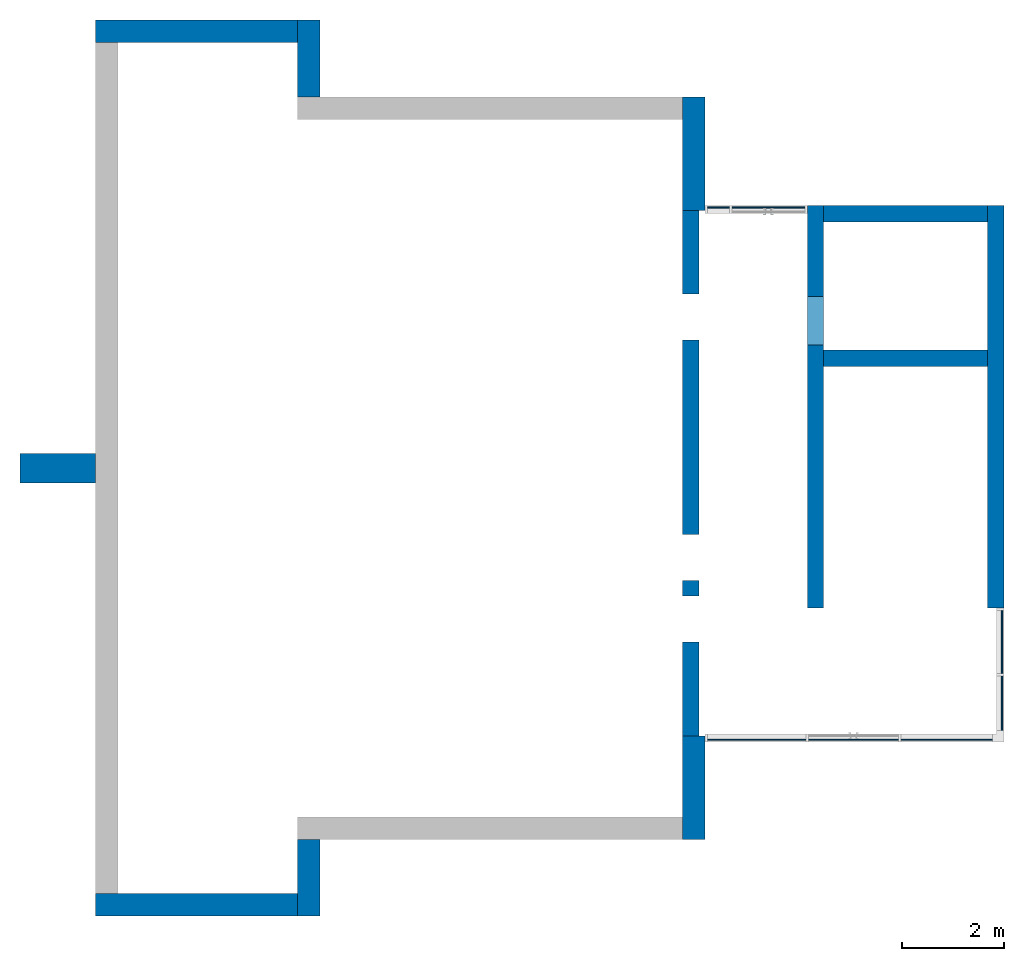
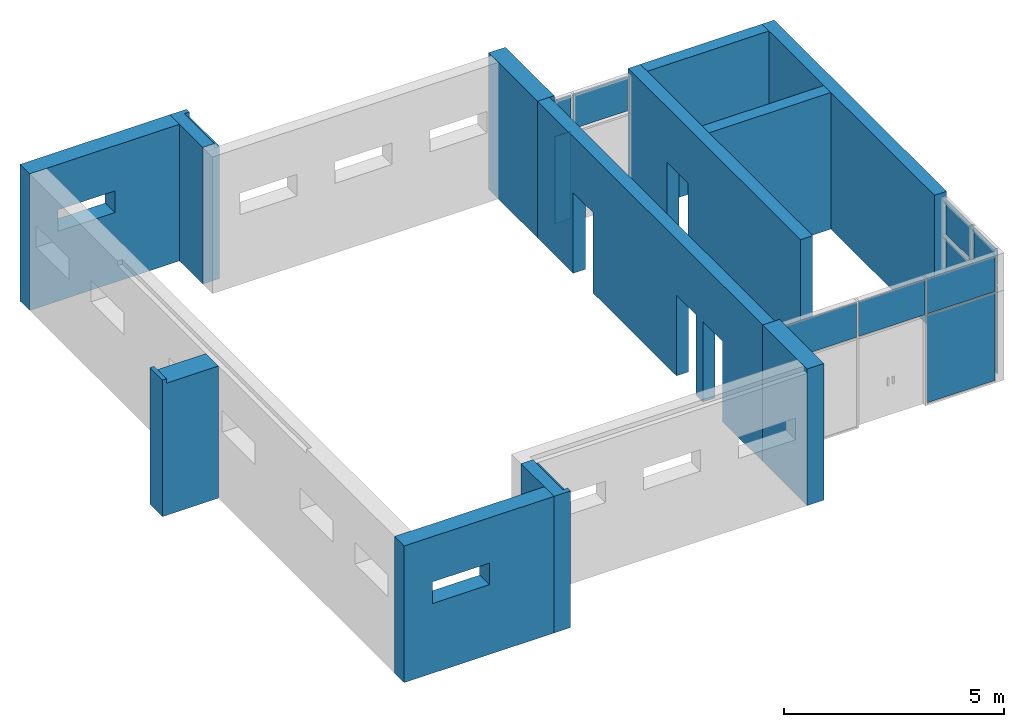
# One storey, part 2 of 4: 12 walls, 11 plates, 6 openings, 3 elements without a shape of their own.
"""IFC2X3 building model written with IfcOpenShell, lengths in millimetres."""

from ifc_helpers import new_model, entity, si_unit, converted_unit, derived_unit, direction, frame, frame_2d, origin, origin_2d_with_axis, place, context, subcontext, project, spatial, polyline, rectangle, extrude, clip, bounded_halfspace, faceted_brep, source, transform, mapped, material, layer, layer_set, layer_usage, type_object, type_shapes, element, aggregate, save


model = new_model("IFC2X3")

# Units and contexts
model_context = context("Model", 3, precision=0.01, world=origin(), true_north=direction((6.12303176911189e-17, 1.0)))
body_context = subcontext(model_context, "Body", "Model", "MODEL_VIEW")
ifc_project = project(units=[si_unit("LENGTHUNIT", "METRE", prefix="MILLI"), si_unit("AREAUNIT", "SQUARE_METRE"), si_unit("VOLUMEUNIT", "CUBIC_METRE"), converted_unit("PLANEANGLEUNIT", "DEGREE", entity("IfcRatioMeasure", 0.0174532925199433), si_unit("PLANEANGLEUNIT", "RADIAN"), dimensions=[0, 0, 0, 0, 0, 0, 0]), si_unit("MASSUNIT", "GRAM", prefix="KILO"), derived_unit("MASSDENSITYUNIT", [(si_unit("MASSUNIT", "GRAM", prefix="KILO"), 1), (si_unit("LENGTHUNIT", "METRE"), -3)]), si_unit("TIMEUNIT", "SECOND"), si_unit("FREQUENCYUNIT", "HERTZ"), si_unit("THERMODYNAMICTEMPERATUREUNIT", "DEGREE_CELSIUS"), derived_unit("THERMALTRANSMITTANCEUNIT", [(si_unit("MASSUNIT", "GRAM", prefix="KILO"), 1), (si_unit("THERMODYNAMICTEMPERATUREUNIT", "KELVIN"), -1), (si_unit("TIMEUNIT", "SECOND"), -3)]), derived_unit("VOLUMETRICFLOWRATEUNIT", [(si_unit("LENGTHUNIT", "METRE"), 3), (si_unit("TIMEUNIT", "SECOND"), -1)]), si_unit("ELECTRICCURRENTUNIT", "AMPERE"), si_unit("ELECTRICVOLTAGEUNIT", "VOLT"), si_unit("POWERUNIT", "WATT"), si_unit("FORCEUNIT", "NEWTON", prefix="KILO"), si_unit("ILLUMINANCEUNIT", "LUX"), si_unit("LUMINOUSFLUXUNIT", "LUMEN"), si_unit("LUMINOUSINTENSITYUNIT", "CANDELA"), derived_unit("USERDEFINED", [(si_unit("MASSUNIT", "GRAM", prefix="KILO"), -1), (si_unit("LENGTHUNIT", "METRE"), -2), (si_unit("TIMEUNIT", "SECOND"), 3), (si_unit("LUMINOUSFLUXUNIT", "LUMEN"), 1)]), derived_unit("LINEARVELOCITYUNIT", [(si_unit("LENGTHUNIT", "METRE"), 1), (si_unit("TIMEUNIT", "SECOND"), -1)]), si_unit("PRESSUREUNIT", "PASCAL"), derived_unit("USERDEFINED", [(si_unit("LENGTHUNIT", "METRE"), -2), (si_unit("MASSUNIT", "GRAM", prefix="KILO"), 1), (si_unit("TIMEUNIT", "SECOND"), -2)])], contexts=[model_context])

# Site, building, storey
site_placement = place(None, origin())
site = spatial("IfcSite", under=ifc_project, at=site_placement, CompositionType="ELEMENT")
building_placement = place(site_placement, origin())
building = spatial("IfcBuilding", under=site, at=building_placement, CompositionType="ELEMENT")
storey_placement = place(building_placement, origin())
storey = spatial("IfcBuildingStorey", under=building, at=storey_placement, Name="00 Ground level", CompositionType="ELEMENT", Elevation=0.0)

# Curtain wall, plates
curtain_wall_type = type_object("IfcCurtainWallType", Name="Curtain Wall", PredefinedType="NOTDEFINED")
curtain_wall_1_placement = place(storey_placement, origin())
curtain_wall_1 = element("IfcCurtainWall", 1, at=curtain_wall_1_placement, inside=storey, type_object=curtain_wall_type, Name="Curtain Wall", ObjectType="Curtain Wall")
ifc_material_1 = material()
ifc_layer_1 = layer(ifc_material_1, 25.0)
ifc_layer_set_1 = layer_set([ifc_layer_1], Name="System Panel:Glazed")
ifc_layer_usage_1 = layer_usage(ifc_layer_set_1, "AXIS3", "POSITIVE", 0.121391076115486)
plate_type_1 = type_object("IfcPlateType", Name="Glazed", PredefinedType="CURTAIN_PANEL", material=ifc_layer_set_1)
shared_shape_1 = source(origin(), body_context, "Body", "SweptSolid", [
    extrude(rectangle(XDim=25.0, YDim=1790.00000000007, at=frame_2d((2.66453525910038e-15, 0.0), x_axis=(1.0, 0.0))), frame((895.0, 12.5, 0.0), z_axis=(0.0, 0.0, 1.0), x_axis=(0.0, 1.0, 0.0)), (0.0, 0.0, 1.0), 2425.0),
])
type_shapes(plate_type_1, [shared_shape_1])
plate_1_placement = place(curtain_wall_1_placement, frame((32768.4900708517, -74150.3241905963, 50.0)))
plate_1 = element("IfcPlate", 2, at=plate_1_placement, type_object=plate_type_1, material=ifc_layer_usage_1, Name="System Panel:Glazed", ObjectType="System Panel:Glazed", context=body_context, shape_type="MappedRepresentation", body=[
    mapped(shared_shape_1, transform((0.0, 0.0, 0.0), scale=1.0)),
])
ifc_layer_usage_2 = layer_usage(ifc_layer_set_1, "AXIS3", "POSITIVE", 0.121391076115486)
plate_type_2 = type_object("IfcPlateType", Name="Glazed", PredefinedType="CURTAIN_PANEL", material=ifc_layer_set_1)
shared_shape_2 = source(origin(), body_context, "Body", "SweptSolid", [
    extrude(rectangle(XDim=25.0, YDim=1924.99999999991, at=frame_2d((2.66453525910038e-15, 0.0), x_axis=(1.0, 0.0))), frame((962.499999999957, 12.5, 0.0), z_axis=(0.0, 0.0, 1.0), x_axis=(0.0, 1.0, 0.0)), (0.0, 0.0, 1.0), 960.0),
])
type_shapes(plate_type_2, [shared_shape_2])
plate_2_placement = place(curtain_wall_1_placement, frame((28993.4900708518, -74150.3241905963, 2525.0)))
plate_2 = element("IfcPlate", 3, at=plate_2_placement, type_object=plate_type_2, material=ifc_layer_usage_2, Name="System Panel:Glazed", ObjectType="System Panel:Glazed", context=body_context, shape_type="MappedRepresentation", body=[
    mapped(shared_shape_2, transform((0.0, 0.0, 0.0), scale=1.0)),
])
ifc_layer_usage_3 = layer_usage(ifc_layer_set_1, "AXIS3", "POSITIVE", 0.121391076115486)
plate_type_3 = type_object("IfcPlateType", Name="Glazed", PredefinedType="CURTAIN_PANEL", material=ifc_layer_set_1)
shared_shape_3 = source(origin(), body_context, "Body", "SweptSolid", [
    extrude(rectangle(XDim=25.0, YDim=1750.0, at=frame_2d((2.66453525910038e-15, 0.0), x_axis=(1.0, 0.0))), frame((875.0, 12.5, 0.0), z_axis=(0.0, 0.0, 1.0), x_axis=(0.0, 1.0, 0.0)), (0.0, 0.0, 1.0), 960.0),
])
type_shapes(plate_type_3, [shared_shape_3])
plate_3_placement = place(curtain_wall_1_placement, frame((30968.4900708517, -74150.3241905963, 2525.0)))
plate_3 = element("IfcPlate", 4, at=plate_3_placement, type_object=plate_type_3, material=ifc_layer_usage_3, Name="System Panel:Glazed", ObjectType="System Panel:Glazed", context=body_context, shape_type="MappedRepresentation", body=[
    mapped(shared_shape_3, transform((0.0, 0.0, 0.0), scale=1.0)),
])
ifc_layer_usage_4 = layer_usage(ifc_layer_set_1, "AXIS3", "POSITIVE", 0.121391076115486)
plate_type_4 = type_object("IfcPlateType", Name="Glazed", PredefinedType="CURTAIN_PANEL", material=ifc_layer_set_1)
shared_shape_4 = source(origin(), body_context, "Body", "SweptSolid", [
    extrude(rectangle(XDim=25.0, YDim=1790.00000000007, at=frame_2d((2.66453525910038e-15, 0.0), x_axis=(1.0, 0.0))), frame((895.0, 12.5, 0.0), z_axis=(0.0, 0.0, 1.0), x_axis=(0.0, 1.0, 0.0)), (0.0, 0.0, 1.0), 960.0),
])
type_shapes(plate_type_4, [shared_shape_4])
plate_4_placement = place(curtain_wall_1_placement, frame((32768.4900708517, -74150.3241905963, 2525.0)))
plate_4 = element("IfcPlate", 5, at=plate_4_placement, type_object=plate_type_4, material=ifc_layer_usage_4, Name="System Panel:Glazed", ObjectType="System Panel:Glazed", context=body_context, shape_type="MappedRepresentation", body=[
    mapped(shared_shape_4, transform((0.0, 0.0, 0.0), scale=1.0)),
])
aggregate(curtain_wall_1, [plate_1, plate_2, plate_3, plate_4])

curtain_wall_2_placement = place(storey_placement, origin())
curtain_wall_2 = element("IfcCurtainWall", 6, at=curtain_wall_2_placement, inside=storey, type_object=curtain_wall_type, Name="Curtain Wall", ObjectType="Curtain Wall")
ifc_layer_usage_5 = layer_usage(ifc_layer_set_1, "AXIS3", "POSITIVE", 0.121391076115486)
plate_type_5 = type_object("IfcPlateType", Name="Glazed", PredefinedType="CURTAIN_PANEL", material=ifc_layer_set_1)
shared_shape_5 = source(origin(), body_context, "Body", "SweptSolid", [
    extrude(rectangle(XDim=25.0, YDim=1057.49999999999, at=origin_2d_with_axis()), frame((528.749999999997, 12.5, 0.0), z_axis=(0.0, 0.0, 1.0), x_axis=(0.0, 1.0, 0.0)), (0.0, 0.0, 1.0), 2425.0),
])
type_shapes(plate_type_5, [shared_shape_5])
plate_5_placement = place(curtain_wall_2_placement, frame((34757.9900708518, -73950.8241905963, 50.0), z_axis=(0.0, 0.0, 1.0), x_axis=(0.0, 1.0, 0.0)))
plate_5 = element("IfcPlate", 7, at=plate_5_placement, type_object=plate_type_5, material=ifc_layer_usage_5, Name="System Panel:Glazed", ObjectType="System Panel:Glazed", context=body_context, shape_type="MappedRepresentation", body=[
    mapped(shared_shape_5, transform((0.0, 0.0, 0.0), scale=1.0)),
])
ifc_layer_usage_6 = layer_usage(ifc_layer_set_1, "AXIS3", "POSITIVE", 0.121391076115486)
plate_type_6 = type_object("IfcPlateType", Name="Glazed", PredefinedType="CURTAIN_PANEL", material=ifc_layer_set_1)
shared_shape_6 = source(origin(), body_context, "Body", "SweptSolid", [
    extrude(rectangle(XDim=25.0, YDim=1232.49999999999, at=frame_2d((-1.77635683940025e-15, 0.0), x_axis=(1.0, 0.0))), frame((616.249999999994, 12.5, 0.0), z_axis=(0.0, 0.0, 1.0), x_axis=(0.0, 1.0, 0.0)), (0.0, 0.0, 1.0), 2425.0),
])
type_shapes(plate_type_6, [shared_shape_6])
plate_6_placement = place(curtain_wall_2_placement, frame((34757.9900708518, -72843.3241905963, 50.0), z_axis=(0.0, 0.0, 1.0), x_axis=(0.0, 1.0, 0.0)))
plate_6 = element("IfcPlate", 8, at=plate_6_placement, type_object=plate_type_6, material=ifc_layer_usage_6, Name="System Panel:Glazed", ObjectType="System Panel:Glazed", context=body_context, shape_type="MappedRepresentation", body=[
    mapped(shared_shape_6, transform((0.0, 0.0, 0.0), scale=1.0)),
])
ifc_layer_usage_7 = layer_usage(ifc_layer_set_1, "AXIS3", "POSITIVE", 0.121391076115486)
plate_type_7 = type_object("IfcPlateType", Name="Glazed", PredefinedType="CURTAIN_PANEL", material=ifc_layer_set_1)
shared_shape_7 = source(origin(), body_context, "Body", "SweptSolid", [
    extrude(rectangle(XDim=25.0, YDim=1057.49999999999, at=origin_2d_with_axis()), frame((528.749999999997, 12.5, 0.0), z_axis=(0.0, 0.0, 1.0), x_axis=(0.0, 1.0, 0.0)), (0.0, 0.0, 1.0), 960.0),
])
type_shapes(plate_type_7, [shared_shape_7])
plate_7_placement = place(curtain_wall_2_placement, frame((34757.9900708518, -73950.8241905963, 2525.0), z_axis=(0.0, 0.0, 1.0), x_axis=(0.0, 1.0, 0.0)))
plate_7 = element("IfcPlate", 9, at=plate_7_placement, type_object=plate_type_7, material=ifc_layer_usage_7, Name="System Panel:Glazed", ObjectType="System Panel:Glazed", context=body_context, shape_type="MappedRepresentation", body=[
    mapped(shared_shape_7, transform((0.0, 0.0, 0.0), scale=1.0)),
])
ifc_layer_usage_8 = layer_usage(ifc_layer_set_1, "AXIS3", "POSITIVE", 0.121391076115486)
plate_type_8 = type_object("IfcPlateType", Name="Glazed", PredefinedType="CURTAIN_PANEL", material=ifc_layer_set_1)
shared_shape_8 = source(origin(), body_context, "Body", "SweptSolid", [
    extrude(rectangle(XDim=25.0, YDim=1232.49999999999, at=frame_2d((-1.77635683940025e-15, 0.0), x_axis=(1.0, 0.0))), frame((616.249999999994, 12.5, 0.0), z_axis=(0.0, 0.0, 1.0), x_axis=(0.0, 1.0, 0.0)), (0.0, 0.0, 1.0), 960.0),
])
type_shapes(plate_type_8, [shared_shape_8])
plate_8_placement = place(curtain_wall_2_placement, frame((34757.9900708518, -72843.3241905963, 2525.0), z_axis=(0.0, 0.0, 1.0), x_axis=(0.0, 1.0, 0.0)))
plate_8 = element("IfcPlate", 10, at=plate_8_placement, type_object=plate_type_8, material=ifc_layer_usage_8, Name="System Panel:Glazed", ObjectType="System Panel:Glazed", context=body_context, shape_type="MappedRepresentation", body=[
    mapped(shared_shape_8, transform((0.0, 0.0, 0.0), scale=1.0)),
])
aggregate(curtain_wall_2, [plate_5, plate_6, plate_7, plate_8])

curtain_wall_3_placement = place(storey_placement, origin())
curtain_wall_3 = element("IfcCurtainWall", 11, at=curtain_wall_3_placement, inside=storey, type_object=curtain_wall_type, Name="Curtain Wall", ObjectType="Curtain Wall")
ifc_layer_usage_9 = layer_usage(ifc_layer_set_1, "AXIS3", "POSITIVE", 0.121391076115486)
plate_type_9 = type_object("IfcPlateType", Name="Glazed", PredefinedType="CURTAIN_PANEL", material=ifc_layer_set_1)
shared_shape_9 = source(origin(), body_context, "Body", "SweptSolid", [
    extrude(rectangle(XDim=25.0, YDim=425.000000000016, at=frame_2d((2.66453525910038e-15, 0.0), x_axis=(1.0, 0.0))), frame((212.500000000008, 12.5, 0.0), z_axis=(0.0, 0.0, 1.0), x_axis=(0.0, 1.0, 0.0)), (0.0, 0.0, 1.0), 2425.0),
])
type_shapes(plate_type_9, [shared_shape_9])
plate_9_placement = place(curtain_wall_3_placement, frame((29418.4900708518, -63731.3241905964, 50.0), z_axis=(0.0, 0.0, 1.0), x_axis=(-1.0, 0.0, 0.0)))
plate_9 = element("IfcPlate", 12, at=plate_9_placement, type_object=plate_type_9, material=ifc_layer_usage_9, Name="System Panel:Glazed", ObjectType="System Panel:Glazed", context=body_context, shape_type="MappedRepresentation", body=[
    mapped(shared_shape_9, transform((0.0, 0.0, 0.0), scale=1.0)),
])
ifc_layer_usage_10 = layer_usage(ifc_layer_set_1, "AXIS3", "POSITIVE", 0.121391076115486)
plate_type_10 = type_object("IfcPlateType", Name="Glazed", PredefinedType="CURTAIN_PANEL", material=ifc_layer_set_1)
shared_shape_10 = source(origin(), body_context, "Body", "SweptSolid", [
    extrude(rectangle(XDim=25.0, YDim=1425.0, at=frame_2d((2.66453525910038e-15, 0.0), x_axis=(1.0, 0.0))), frame((712.5, 12.5, 0.0), z_axis=(0.0, 0.0, 1.0), x_axis=(0.0, 1.0, 0.0)), (0.0, 0.0, 1.0), 960.0),
])
type_shapes(plate_type_10, [shared_shape_10])
plate_10_placement = place(curtain_wall_3_placement, frame((30893.4900708518, -63731.3241905964, 2525.0), z_axis=(0.0, 0.0, 1.0), x_axis=(-1.0, 0.0, 0.0)))
plate_10 = element("IfcPlate", 13, at=plate_10_placement, type_object=plate_type_10, material=ifc_layer_usage_10, Name="System Panel:Glazed", ObjectType="System Panel:Glazed", context=body_context, shape_type="MappedRepresentation", body=[
    mapped(shared_shape_10, transform((0.0, 0.0, 0.0), scale=1.0)),
])
ifc_layer_usage_11 = layer_usage(ifc_layer_set_1, "AXIS3", "POSITIVE", 0.121391076115486)
plate_type_11 = type_object("IfcPlateType", Name="Glazed", PredefinedType="CURTAIN_PANEL", material=ifc_layer_set_1)
shared_shape_11 = source(origin(), body_context, "Body", "SweptSolid", [
    extrude(rectangle(XDim=25.0, YDim=425.000000000016, at=frame_2d((2.66453525910038e-15, 0.0), x_axis=(1.0, 0.0))), frame((212.500000000008, 12.5, 0.0), z_axis=(0.0, 0.0, 1.0), x_axis=(0.0, 1.0, 0.0)), (0.0, 0.0, 1.0), 960.0),
])
type_shapes(plate_type_11, [shared_shape_11])
plate_11_placement = place(curtain_wall_3_placement, frame((29418.4900708518, -63731.3241905964, 2525.0), z_axis=(0.0, 0.0, 1.0), x_axis=(-1.0, 0.0, 0.0)))
plate_11 = element("IfcPlate", 14, at=plate_11_placement, type_object=plate_type_11, material=ifc_layer_usage_11, Name="System Panel:Glazed", ObjectType="System Panel:Glazed", context=body_context, shape_type="MappedRepresentation", body=[
    mapped(shared_shape_11, transform((0.0, 0.0, 0.0), scale=1.0)),
])
aggregate(curtain_wall_3, [plate_9, plate_10, plate_11])

# Walls
ifc_material_2 = material(Name="03")
ifc_layer_2 = layer(ifc_material_2, 10.0)
ifc_material_3 = material()
ifc_layer_3 = layer(ifc_material_3, 120.0)
ifc_material_4 = material()
ifc_layer_4 = layer(ifc_material_4, 300.0)
ifc_layer_5 = layer(ifc_material_2, 10.0)
ifc_layer_set_2 = layer_set([ifc_layer_2, ifc_layer_3, ifc_layer_4, ifc_layer_5], Name="Basic Wall:00_fal+12 cm")
ifc_layer_usage_12 = layer_usage(ifc_layer_set_2, "AXIS2", "NEGATIVE", 220.0)
wall_type_1 = type_object("IfcWallType", Name="Basic Wall:00_fal+12 cm", PredefinedType="STANDARD", material=ifc_layer_set_2)
wall_1_placement = place(storey_placement, frame((28723.4900708518, -61581.23958514, -140.0), z_axis=(0.0, 0.0, 1.0), x_axis=(0.0, -1.0, 0.0)))
element("IfcWallStandardCase", 15, at=wall_1_placement, inside=storey, type_object=wall_type_1, material=ifc_layer_usage_12, Name="Basic Wall:00_fal+12 cm", ObjectType="Basic Wall:00_fal+12 cm", context=body_context, shape_type="SweptSolid", body=[
    extrude(rectangle(XDim=2224.58460545637, YDim=440.000000000004, at=frame_2d((1112.29230272819, -1.84741111297626e-13), x_axis=(-1.0, 0.0))), origin(), (0.0, 0.0, 1.0), 3800.0),
])
wall_2_placement = place(storey_placement, frame((21203.4900708518, -76081.2395851399, -140.0), z_axis=(0.0, 0.0, 1.0), x_axis=(0.0, -1.0, 0.0)))
element("IfcWall", 16, at=wall_2_placement, inside=storey, type_object=wall_type_1, Name="Basic Wall:00_fal+12 cm", ObjectType="Basic Wall:00_fal+12 cm", context=body_context, shape_type="Brep", body=[
    faceted_brep([(0.0, -220.0, 0.0), (1060.0, -220.0, 0.0), (1500.0, -220.0, 0.0), (1500.0, -220.0, 3800.0), (1370.0, -220.0, 3800.0), (1060.0, -220.0, 3800.0), (0.0, -220.0, 3800.0), (1500.0, 220.0, 0.0), (0.0, 220.0, 0.0), (0.0, 220.0, 3675.0), (1370.0, 220.0, 3675.0), (1370.0, 220.0, 3800.0), (1500.0, 220.0, 3800.0), (1370.0, 90.0, 3800.0), (0.0, 90.0, 3800.0), (0.0, 90.0, 3675.0), (1370.0, 90.0, 3675.0)], [[[0, 1, 2, 3, 4, 5, 6]], [[7, 8, 9, 10, 11, 12]], [[2, 1, 0, 8, 7]], [[6, 5, 4, 3, 12, 11, 13, 14]], [[0, 6, 14, 15, 9, 8]], [[3, 2, 7, 12]], [[15, 16, 10, 9]], [[16, 13, 11, 10]], [[13, 16, 15, 14]]]),
])

# Wall, opening
ifc_layer_usage_13 = layer_usage(ifc_layer_set_2, "AXIS2", "NEGATIVE", 220.0)
wall_3_placement = place(storey_placement, frame((20983.4900708518, -77361.2395851399, -140.0), z_axis=(0.0, 0.0, 1.0), x_axis=(-1.0, 0.0, 0.0)))
wall_3 = element("IfcWallStandardCase", 17, at=wall_3_placement, inside=storey, type_object=wall_type_1, material=ifc_layer_usage_13, Name="Basic Wall:00_fal+12 cm", ObjectType="Basic Wall:00_fal+12 cm", context=body_context, shape_type="SweptSolid", body=[
    extrude(rectangle(XDim=3940.00000000002, YDim=440.000000000004, at=frame_2d((1970.00000000001, 0.0), x_axis=(-1.0, 0.0))), origin(), (0.0, 0.0, 1.0), 3800.0),
])
opening_1_placement = place(wall_3_placement, frame((3200.0, 1744.0, 1940.0), z_axis=(0.0, 0.0, 1.0), x_axis=(-1.0, 0.0, 0.0)))
element("IfcOpeningElement", 18, at=opening_1_placement, cuts=wall_3, Name="Basic Wall:00_fal+12 cm", ObjectType="Opening", context=body_context, shape_type="SweptSolid", body=[
    extrude(rectangle(XDim=599.999999999998, YDim=1500.0, at=frame_2d((0.0, 0.0), x_axis=(0.0, 1.0))), frame((750.0, 3048.0, 300.0), z_axis=(0.0, -1.0, 0.0), x_axis=(1.0, 0.0, 0.0)), (0.0, 0.0, 1.0), 3048.0),
])

# Wall
wall_4_placement = place(storey_placement, frame((21203.4900708518, -61581.2395851399, -140.0), z_axis=(0.0, 0.0, 1.0), x_axis=(0.0, 1.0, 0.0)))
element("IfcWall", 19, at=wall_4_placement, inside=storey, type_object=wall_type_1, Name="Basic Wall:00_fal+12 cm", ObjectType="Basic Wall:00_fal+12 cm", context=body_context, shape_type="Brep", body=[
    faceted_brep([(0.0, -220.0, 0.0), (1500.0, -220.0, 0.0), (1500.0, -220.0, 3800.0), (1370.0, -220.0, 3800.0), (1370.0, -220.0, 3675.0), (0.0, -220.0, 3675.0), (1500.0, 220.0, 0.0), (1060.0, 220.0, 0.0), (0.0, 220.0, 0.0), (0.0, 220.0, 3800.0), (1060.0, 220.0, 3800.0), (1370.0, 220.0, 3800.0), (1500.0, 220.0, 3800.0), (0.0, -90.0, 3800.0), (1370.0, -90.0, 3800.0), (0.0, -90.0, 3675.0), (1370.0, -90.0, 3675.0)], [[[0, 1, 2, 3, 4, 5]], [[6, 7, 8, 9, 10, 11, 12]], [[1, 0, 8, 7, 6]], [[12, 11, 10, 9, 13, 14, 3, 2]], [[9, 8, 0, 5, 15, 13]], [[2, 1, 6, 12]], [[4, 16, 15, 5]], [[16, 14, 13, 15]], [[14, 16, 4, 3]]]),
])

# Wall, opening
ifc_layer_usage_14 = layer_usage(ifc_layer_set_2, "AXIS2", "POSITIVE", -220.0)
wall_5_placement = place(storey_placement, frame((20983.4900708518, -60301.2395851399, -140.0), z_axis=(0.0, 0.0, 1.0), x_axis=(-1.0, 0.0, 0.0)))
wall_5 = element("IfcWallStandardCase", 20, at=wall_5_placement, inside=storey, type_object=wall_type_1, material=ifc_layer_usage_14, Name="Basic Wall:00_fal+12 cm", ObjectType="Basic Wall:00_fal+12 cm", context=body_context, shape_type="SweptSolid", body=[
    extrude(rectangle(XDim=3940.00000000004, YDim=440.000000000004, at=frame_2d((1970.00000000002, -1.08002495835535e-12), x_axis=(-1.0, 0.0))), origin(), (0.0, 0.0, 1.0), 3800.0),
])
opening_2_placement = place(wall_5_placement, frame((3200.0, 1304.0, 1940.0), z_axis=(0.0, 0.0, 1.0), x_axis=(-1.0, 0.0, 0.0)))
element("IfcOpeningElement", 21, at=opening_2_placement, cuts=wall_5, Name="Basic Wall:00_fal+12 cm", ObjectType="Opening", context=body_context, shape_type="SweptSolid", body=[
    extrude(rectangle(XDim=599.999999999998, YDim=1500.0, at=frame_2d((0.0, 0.0), x_axis=(0.0, 1.0))), frame((750.0, 3048.0, 300.0), z_axis=(0.0, -1.0, 0.0), x_axis=(1.0, 0.0, 0.0)), (0.0, 0.0, 1.0), 3048.0),
])

# Wall
ifc_layer_usage_15 = layer_usage(ifc_layer_set_2, "AXIS2", "NEGATIVE", 220.0)
wall_6_placement = place(storey_placement, frame((28723.4900708518, -74061.2395851399, -140.0), z_axis=(0.0, 0.0, 1.0), x_axis=(0.0, -1.0, 0.0)))
element("IfcWallStandardCase", 22, at=wall_6_placement, inside=storey, type_object=wall_type_1, material=ifc_layer_usage_15, Name="Basic Wall:00_fal+12 cm", ObjectType="Basic Wall:00_fal+12 cm", context=body_context, shape_type="SweptSolid", body=[
    extrude(rectangle(XDim=2020.0, YDim=440.000000000004, at=frame_2d((1010.0, -3.69482222595252e-13), x_axis=(-1.0, 0.0))), origin(), (0.0, 0.0, 1.0), 3800.0),
])

# Wall, opening
ifc_layer_6 = layer(ifc_material_2, 10.0)
ifc_layer_7 = layer(ifc_material_4, 300.0)
ifc_layer_8 = layer(ifc_material_2, 10.0)
ifc_layer_set_3 = layer_set([ifc_layer_6, ifc_layer_7, ifc_layer_8], Name="Basic Wall:00_fal 300 mm")
ifc_layer_usage_16 = layer_usage(ifc_layer_set_3, "AXIS2", "NEGATIVE", 160.0)
wall_type_2 = type_object("IfcWallType", Name="Basic Wall:00_fal 300 mm", PredefinedType="STANDARD", material=ifc_layer_set_3)
wall_7_placement = place(storey_placement, frame((31103.4900708518, -63705.8241905964, -140.0), z_axis=(0.0, 0.0, 1.0), x_axis=(0.0, -1.0, 0.0)))
wall_7 = element("IfcWallStandardCase", 23, at=wall_7_placement, inside=storey, type_object=wall_type_2, material=ifc_layer_usage_16, Name="Basic Wall:00_fal 300 mm", ObjectType="Basic Wall:00_fal 300 mm", context=body_context, shape_type="SweptSolid", body=[
    extrude(rectangle(XDim=7854.99999999996, YDim=319.999999999997, at=frame_2d((3927.49999999998, -6.53699316899292e-13), x_axis=(-1.0, 0.0))), origin(), (0.0, 0.0, 1.0), 3800.0),
])
opening_3_placement = place(wall_7_placement, frame((2720.0, -1684.0, 140.0), z_axis=(0.0, 0.0, 1.0), x_axis=(0.0, 1.0, 0.0)))
element("IfcOpeningElement", 24, at=opening_3_placement, cuts=wall_7, Name="Basic Wall:00_fal 300 mm", ObjectType="Opening", context=body_context, shape_type="SweptSolid", body=[
    extrude(rectangle(XDim=2125.0, YDim=950.000000000001, at=frame_2d((4.34852154285181e-12, 0.0), x_axis=(0.0, 1.0))), frame((0.0, 475.0, 1062.5), z_axis=(1.0, 0.0, 0.0), x_axis=(0.0, 1.0, 0.0)), (0.0, 0.0, 1.0), 3048.0),
])

# Walls
ifc_layer_usage_17 = layer_usage(ifc_layer_set_3, "AXIS2", "NEGATIVE", 160.0)
wall_8_placement = place(storey_placement, frame((31263.4900708518, -66685.8241905964, -140.0)))
element("IfcWallStandardCase", 25, at=wall_8_placement, inside=storey, type_object=wall_type_2, material=ifc_layer_usage_17, Name="Basic Wall:00_fal 300 mm", ObjectType="Basic Wall:00_fal 300 mm", context=body_context, shape_type="SweptSolid", body=[
    extrude(rectangle(XDim=3199.99999999998, YDim=319.999999999997, at=frame_2d((1599.99999999999, 1.406874616805e-12), x_axis=(-1.0, 0.0))), origin(), (0.0, 0.0, 1.0), 3800.0),
])
ifc_layer_usage_18 = layer_usage(ifc_layer_set_3, "AXIS2", "NEGATIVE", 160.0)
wall_9_placement = place(storey_placement, frame((34623.4900708518, -63705.8241905964, -140.0), z_axis=(0.0, 0.0, 1.0), x_axis=(0.0, -1.0, 0.0)))
element("IfcWallStandardCase", 26, at=wall_9_placement, inside=storey, type_object=wall_type_2, material=ifc_layer_usage_18, Name="Basic Wall:00_fal 300 mm", ObjectType="Basic Wall:00_fal 300 mm", context=body_context, shape_type="SweptSolid", body=[
    extrude(rectangle(XDim=7854.99999999996, YDim=319.999999999997, at=frame_2d((3927.49999999998, -6.53699316899292e-13), x_axis=(-1.0, 0.0))), origin(), (0.0, 0.0, 1.0), 3800.0),
])
ifc_layer_usage_19 = layer_usage(ifc_layer_set_3, "AXIS2", "NEGATIVE", 160.0)
wall_10_placement = place(storey_placement, frame((31263.4900708518, -63865.8241905964, -140.0)))
element("IfcWallStandardCase", 27, at=wall_10_placement, inside=storey, type_object=wall_type_2, material=ifc_layer_usage_19, Name="Basic Wall:00_fal 300 mm", ObjectType="Basic Wall:00_fal 300 mm", context=body_context, shape_type="SweptSolid", body=[
    extrude(rectangle(XDim=3199.99999999998, YDim=319.999999999997, at=frame_2d((1599.99999999999, 0.0), x_axis=(-1.0, 0.0))), origin(), (0.0, 0.0, 1.0), 3800.0),
])

# Wall, openings
ifc_layer_usage_20 = layer_usage(ifc_layer_set_3, "AXIS2", "NEGATIVE", 160.0)
wall_11_placement = place(storey_placement, frame((28663.4900708518, -63805.8241905963, -140.0), z_axis=(0.0, 0.0, 1.0), x_axis=(0.0, -1.0, 0.0)))
wall_11 = element("IfcWallStandardCase", 28, at=wall_11_placement, inside=storey, type_object=wall_type_2, material=ifc_layer_usage_20, Name="Basic Wall:00_fal 300 mm", ObjectType="Basic Wall:00_fal 300 mm", context=body_context, shape_type="SweptSolid", body=[
    extrude(rectangle(XDim=10255.4153945436, YDim=319.999999999997, at=frame_2d((5127.70769727178, 4.83169060316868e-13), x_axis=(-1.0, 0.0))), origin(), (0.0, 0.0, 1.0), 3800.0),
])
opening_4_placement = place(wall_11_placement, frame((8425.41539454361, -1364.0, 0.0), z_axis=(0.0, 0.0, 1.0), x_axis=(0.0, 1.0, 0.0)))
element("IfcOpeningElement", 29, at=opening_4_placement, cuts=wall_11, Name="Basic Wall:00_fal 300 mm", ObjectType="Opening", context=body_context, shape_type="SweptSolid", body=[
    extrude(rectangle(XDim=2240.0, YDim=900.000000000003, at=frame_2d((0.0, 0.0), x_axis=(0.0, 1.0))), frame((0.0, 450.0, 1120.0), z_axis=(1.0, 0.0, 0.0), x_axis=(0.0, 1.0, 0.0)), (0.0, 0.0, 1.0), 3048.0),
])
opening_5_placement = place(wall_11_placement, frame((7225.41539454361, -1364.0, 0.0), z_axis=(0.0, 0.0, 1.0), x_axis=(0.0, 1.0, 0.0)))
element("IfcOpeningElement", 30, at=opening_5_placement, cuts=wall_11, Name="Basic Wall:00_fal 300 mm", ObjectType="Opening", context=body_context, shape_type="SweptSolid", body=[
    extrude(rectangle(XDim=2240.0, YDim=900.000000000003, at=origin_2d_with_axis()), frame((0.0, 450.0, 1120.0), z_axis=(1.0, 0.0, 0.0), x_axis=(0.0, 0.0, 1.0)), (0.0, 0.0, 1.0), 3048.0),
])
opening_6_placement = place(wall_11_placement, frame((2525.4153945436, -1364.0, 0.0), z_axis=(0.0, 0.0, 1.0), x_axis=(0.0, 1.0, 0.0)))
element("IfcOpeningElement", 31, at=opening_6_placement, cuts=wall_11, Name="Basic Wall:00_fal 300 mm", ObjectType="Opening", context=body_context, shape_type="SweptSolid", body=[
    extrude(rectangle(XDim=2240.0, YDim=900.000000000003, at=origin_2d_with_axis()), frame((0.0, 450.0, 1120.0), z_axis=(1.0, 0.0, 0.0), x_axis=(0.0, 0.0, 1.0)), (0.0, 0.0, 1.0), 3048.0),
])

# Wall
ifc_layer_9 = layer(ifc_material_2, 10.0)
ifc_material_5 = material(Name="06_ APP")
ifc_layer_10 = layer(ifc_material_5, 10.0)
ifc_layer_11 = layer(ifc_material_3, 120.0)
ifc_layer_12 = layer(ifc_material_4, 300.0)
ifc_material_6 = material()
ifc_layer_13 = layer(ifc_material_6, 120.0)
ifc_layer_14 = layer(ifc_material_2, 10.0)
ifc_layer_set_4 = layer_set([ifc_layer_9, ifc_layer_10, ifc_layer_11, ifc_layer_12, ifc_layer_13, ifc_layer_14], Name="Basic Wall:00_fal+2x12 cm")
ifc_layer_usage_21 = layer_usage(ifc_layer_set_4, "AXIS2", "NEGATIVE", 285.0)
wall_type_3 = type_object("IfcWallType", Name="Basic Wall:00_fal+2x12 cm", PredefinedType="STANDARD", material=ifc_layer_set_4)
wall_12_placement = place(storey_placement, frame((17043.4900708518, -68836.2395851399, -140.0), z_axis=(0.0, 0.0, 1.0), x_axis=(-1.0, 0.0, 0.0)))
element("IfcWallStandardCase", 32, at=wall_12_placement, inside=storey, type_object=wall_type_3, material=ifc_layer_usage_21, Name="Basic Wall:00_fal+2x12 cm", ObjectType="Basic Wall:00_fal+2x12 cm", context=body_context, shape_type="Clipping", body=[
    clip(clip(extrude(rectangle(XDim=1474.99999999999, YDim=569.999999999992, at=frame_2d((737.499999999994, -5.6843418860808e-13), x_axis=(-1.0, 0.0))), origin(), (0.0, 0.0, 1.0), 3800.0), bounded_halfspace(frame((1370.0, -285.0, 3675.0), z_axis=(0.0, 0.0, -1.0), x_axis=(-1.0, 0.0, 0.0)), True, frame((1370.0, -285.0, 3675.0), z_axis=(0.0, 0.0, -1.0), x_axis=(-1.0, 0.0, 0.0)), polyline([(0.0, 0.0), (1370.0, 0.0), (1370.0, 570.0), (0.0, 570.0), (0.0, 0.0)]))), bounded_halfspace(frame((1370.0, 285.0, 3675.0), z_axis=(1.0, 0.0, 0.0), x_axis=(0.0, 0.0, 1.0)), True, frame((1370.0, 285.0, 3675.0), z_axis=(1.0, 0.0, 0.0), x_axis=(0.0, 0.0, 1.0)), polyline([(0.0, 0.0), (125.0, 0.0), (125.0, 570.0), (0.0, 570.0), (0.0, 0.0)]))),
])

save(model, "model.ifc")
